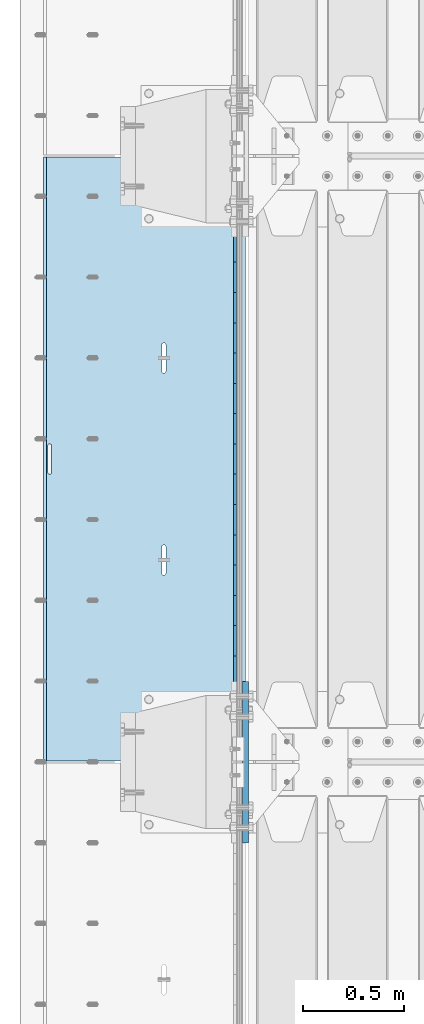
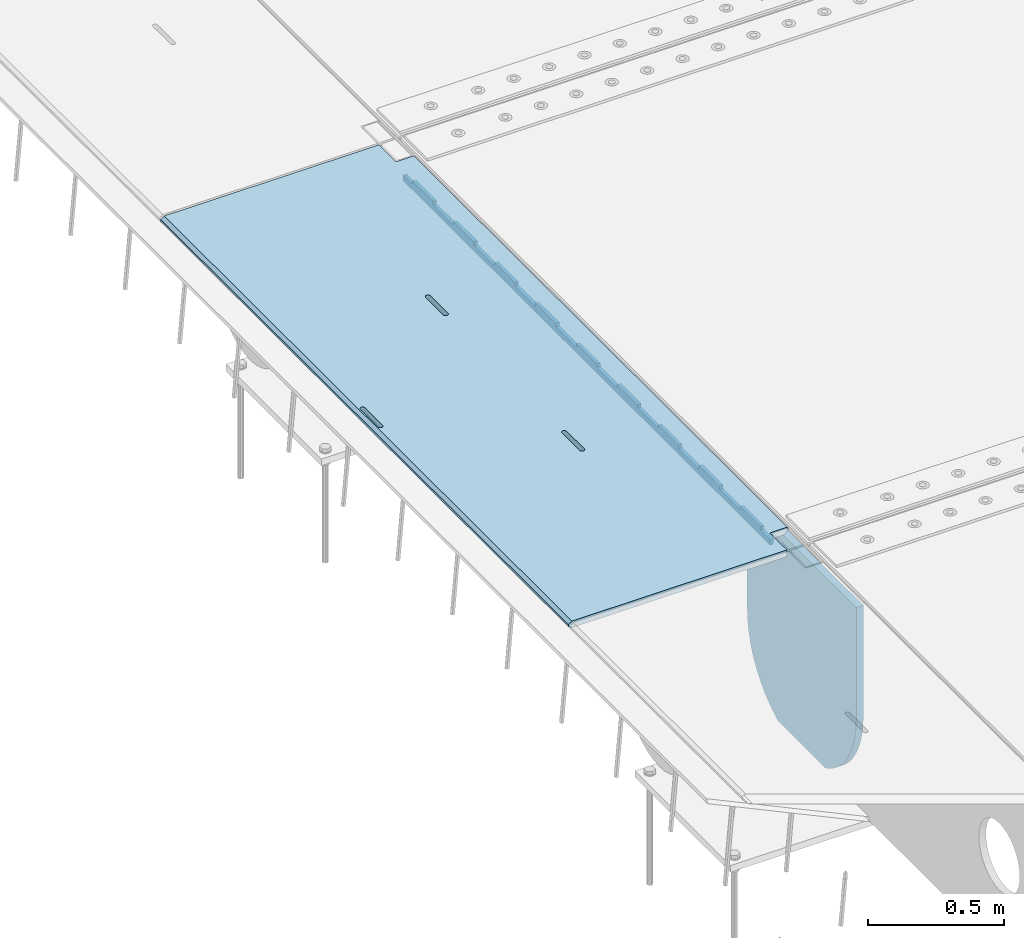
# One storey, part 185 of 240: 3 plates.
"""IFC2X3 building model written with IfcOpenShell, lengths in millimetres."""

from ifc_helpers import new_model, si_unit, frame, origin_with_axes, place, context, subcontext, project, spatial, faceted_brep, material, type_object, element, save


model = new_model("IFC2X3")

# Units and contexts
model_context = context("Model", 3, precision=1e-05, world=origin_with_axes())
body_context = subcontext(model_context, "Body", "Model", "MODEL_VIEW")
ifc_project = project(units=[si_unit("LENGTHUNIT", "METRE", prefix="MILLI"), si_unit("AREAUNIT", "SQUARE_METRE"), si_unit("VOLUMEUNIT", "CUBIC_METRE"), si_unit("MASSUNIT", "GRAM", prefix="KILO"), si_unit("TIMEUNIT", "SECOND"), si_unit("PLANEANGLEUNIT", "RADIAN"), si_unit("SOLIDANGLEUNIT", "STERADIAN"), si_unit("THERMODYNAMICTEMPERATUREUNIT", "DEGREE_CELSIUS"), si_unit("LUMINOUSINTENSITYUNIT", "LUMEN")], contexts=[model_context])

# Site, building, storey
site_placement = place(None, origin_with_axes())
site = spatial("IfcSite", under=ifc_project, at=site_placement, CompositionType="ELEMENT")
building_placement = place(site_placement, origin_with_axes())
building = spatial("IfcBuilding", under=site, at=building_placement, Name="Standard", CompositionType="ELEMENT")
storey_placement = place(building_placement, origin_with_axes())
storey = spatial("IfcBuildingStorey", under=building, at=storey_placement, Name="Undefined", CompositionType="ELEMENT", Elevation=0.0)

# Plates
ifc_material = material(Name="STEEL/S355N")
plate_type_1 = type_object("IfcPlateType", PredefinedType="NOTDEFINED")
plate_1_placement = place(storey_placement, frame((42392.5, 29845.0000994564, -36.018454190458), z_axis=(0.0, -0.999999999987744, -4.95099999993769e-06), x_axis=(0.0, 4.9510000093107e-06, -0.999999999987744)))
element("IfcPlate", 1, at=plate_1_placement, inside=storey, type_object=plate_type_1, material=ifc_material, context=body_context, shape_type="Brep", body=[
    faceted_brep([(7.105427357601e-15, -7.5, 0.0), (-1.24849464100407e-10, -7.5, 70.0), (-1.24849464100407e-10, 7.5, 70.0), (7.105427357601e-15, 7.5, 0.0), (-14.9899997711175, -7.5, 70.0), (-14.9899997711175, 7.5, 70.0), (-14.9899997711161, -7.5, 219.999999999996), (-14.9899997711161, 7.5, 219.999999999996), (-3.90826926377486e-10, -7.5, 220.0), (-3.90826926377486e-10, 7.5, 220.0), (-6.56825704936637e-10, -7.5, 369.999999999996), (-6.56825704936637e-10, 7.5, 369.999999999996), (-14.9899997711147, -7.5, 370.0), (-14.9899997711147, 7.5, 370.0), (-14.9899997711133, -7.5, 520.0), (-14.9899997711133, 7.5, 520.0), (-9.24622156617261e-10, -7.5, 520.0), (-9.24622156617261e-10, 7.5, 520.0), (-1.1906067243217e-09, -7.5, 670.0), (-1.1906067243217e-09, 7.5, 670.0), (-14.9899997711119, -7.5, 670.0), (-14.9899997711119, 7.5, 670.0), (-14.9899997711105, -7.5, 820.0), (-14.9899997711105, 7.5, 820.0), (-1.45477230262259e-09, -7.5, 819.999999999996), (-1.45477230262259e-09, 7.5, 819.999999999996), (-1.72258296515793e-09, -7.5, 970.0), (-1.72258296515793e-09, 7.5, 970.0), (-14.9899997711091, -7.5, 970.0), (-14.9899997711091, 7.5, 970.0), (-14.9899997711077, -7.5, 1120.0), (-14.9899997711077, 7.5, 1120.0), (-1.988560427435e-09, -7.5, 1120.0), (-1.988560427435e-09, 7.5, 1120.0), (-2.2545521005668e-09, -7.5, 1270.0), (-2.2545521005668e-09, 7.5, 1270.0), (-14.9899997711063, -7.5, 1270.0), (-14.9899997711063, 7.5, 1270.0), (-14.9899997711048, -7.5, 1420.0), (-14.9899997711048, 7.5, 1420.0), (-2.52235565767478e-09, -7.5, 1420.0), (-2.52235565767478e-09, 7.5, 1420.0), (-2.78834733080657e-09, -7.5, 1570.0), (-2.78834733080657e-09, 7.5, 1570.0), (-14.9899997711034, -7.5, 1570.0), (-14.9899997711034, 7.5, 1570.0), (-14.989999771102, -7.5, 1720.0), (-14.989999771102, 7.5, 1720.0), (-3.05432479308365e-09, -7.5, 1720.0), (-3.05432479308365e-09, 7.5, 1720.0), (-3.32212835019163e-09, -7.5, 1870.0), (-3.32212835019163e-09, 7.5, 1870.0), (-14.9899997711006, -7.5, 1870.0), (-14.9899997711006, 7.5, 1870.0), (-14.9899997710992, -7.5, 2020.0), (-14.9899997710992, 7.5, 2020.0), (-3.58812002332343e-09, -7.5, 2020.0), (-3.58812002332343e-09, 7.5, 2020.0), (-3.85410459102786e-09, -7.5, 2170.0), (-3.85410459102786e-09, 7.5, 2170.0), (-14.9899997710978, -7.5, 2170.0), (-14.9899997710978, 7.5, 2170.0), (-14.9899997710964, -7.5, 2320.0), (-14.9899997710964, 7.5, 2320.0), (-4.12190104270849e-09, -7.5, 2320.0), (-4.12190104270849e-09, 7.5, 2320.0), (-4.38789982126764e-09, -7.5, 2470.0), (-4.38789982126764e-09, 7.5, 2470.0), (-14.9999999999768, -7.5, 2470.0), (-14.9999999999768, 7.5, 2470.0), (-14.9899997710936, -7.5, 2620.0), (-14.9899997710936, 7.5, 2620.0), (-4.65387728354472e-09, -7.5, 2620.0), (-4.65387728354472e-09, 7.5, 2620.0), (-4.77872674764512e-09, -7.5, 2690.0), (-4.77872674764512e-09, 7.5, 2690.0), (25.0100002289071, -7.5, 2690.0), (25.0100002289071, 7.5, 2690.0), (25.0, -7.5, 0.0), (25.0, 7.5, 0.0)], [[[0, 1, 2, 3]], [[1, 4, 5, 2]], [[4, 6, 7, 5]], [[6, 8, 9, 7]], [[8, 10, 11, 9]], [[10, 12, 13, 11]], [[12, 14, 15, 13]], [[14, 16, 17, 15]], [[16, 18, 19, 17]], [[18, 20, 21, 19]], [[20, 22, 23, 21]], [[22, 24, 25, 23]], [[24, 26, 27, 25]], [[26, 28, 29, 27]], [[28, 30, 31, 29]], [[30, 32, 33, 31]], [[32, 34, 35, 33]], [[34, 36, 37, 35]], [[36, 38, 39, 37]], [[38, 40, 41, 39]], [[40, 42, 43, 41]], [[42, 44, 45, 43]], [[44, 46, 47, 45]], [[46, 48, 49, 47]], [[48, 50, 51, 49]], [[50, 52, 53, 51]], [[52, 54, 55, 53]], [[54, 56, 57, 55]], [[56, 58, 59, 57]], [[58, 60, 61, 59]], [[60, 62, 63, 61]], [[62, 64, 65, 63]], [[64, 66, 67, 65]], [[66, 68, 69, 67]], [[68, 70, 71, 69]], [[70, 72, 73, 71]], [[72, 74, 75, 73]], [[74, 76, 77, 75]], [[76, 78, 79, 77]], [[78, 0, 3, 79]], [[5, 7, 9, 11, 13, 15, 17, 19, 21, 23, 25, 27, 29, 31, 33, 35, 37, 39, 41, 43, 45, 47, 49, 51, 53, 55, 57, 59, 61, 63, 65, 67, 69, 71, 73, 75, 77, 79, 3, 2]], [[78, 76, 74, 72, 70, 68, 66, 64, 62, 60, 58, 56, 54, 52, 50, 48, 46, 44, 42, 40, 38, 36, 34, 32, 30, 28, 26, 24, 22, 20, 18, 16, 14, 12, 10, 8, 6, 4, 1, 0]]]),
])
plate_type_2 = type_object("IfcPlateType", PredefinedType="NOTDEFINED")
plate_2_placement = place(storey_placement, frame((42444.9962456697, 29994.9999261728, -1.00003031100477), z_axis=(0.0, -0.999999999987744, -4.95099999993769e-06), x_axis=(-0.999999999879068, -1.00000022173607e-09, -1.55519999981193e-05)))
element("IfcPlate", 2, at=plate_2_placement, inside=storey, type_object=plate_type_2, material=ifc_material, context=body_context, shape_type="Brep", body=[
    faceted_brep([(-0.000111589528387412, -5.71507111812863e-05, 2865.00000504127), (15.000238879169, 15.0, 2865.00008049106), (15.0000104223145, 15.0, 125.000079348185), (-0.000225737421715166, 5.71560163176166e-05, 125.00000363258), (999.996459960938, 5.0, 0.0), (984.996459960938, 15.0, 3.63797880709171e-12), (984.996459730719, 15.0, 2990.0), (999.996459730726, 5.0, 2990.0), (999.996459730726, -5.0, 2990.0), (984.99645973053, -15.0, 2990.0), (984.996459961367, -15.0, 0.0), (999.996459960938, -4.99999999999849, 0.0), (959.999522276543, -15.0000000031848, 1560.00000000859), (959.999522276543, 15.0, 1560.00000000858), (960.488957113346, 15.0, 1563.09016995233), (960.488957113346, -15.0000000031888, 1563.09016995233), (961.909352332339, 15.0, 1565.87785253151), (961.909352332339, -15.0000000032008, 1565.87785253151), (964.121669752989, 15.0, 1568.09016995233), (964.121669752989, -15.0000000032196, 1568.09016995233), (966.909352332048, 15.0, 1569.51056517153), (966.909352332055, -15.0000000032433, 1569.51056517153), (969.99952227575, 15.0, 1570.00000000859), (969.999522275757, -15.0000000032698, 1570.00000000859), (973.089692219539, 15.0, 1569.51056517153), (973.089692219546, -15.0000000032963, 1569.51056517154), (975.877374798838, 15.0, 1568.09016995233), (975.877374798831, -15.0000000033202, 1568.09016995233), (978.08969221983, 15.0, 1565.87785253151), (978.089692219837, -15.0000000033393, 1565.87785253151), (979.510087439237, 15.0, 1563.09016995232), (979.510087439237, -15.0000000033517, 1563.09016995232), (979.999522276528, 15.0, 1560.00000000857), (979.999522276528, -15.0000000033561, 1560.00000000857), (979.999522286394, 15.0, 1430.00000000857), (979.999522286394, -15.0000000033654, 1430.00000000857), (979.510087449584, 15.0, 1426.90983006483), (979.510087449584, -15.0000000033615, 1426.90983006483), (978.089692230598, 15.0, 1424.12214748565), (978.089692230591, -15.0000000033495, 1424.12214748566), (975.877374809941, 15.0, 1421.90983006484), (975.877374809941, -15.0000000033307, 1421.90983006483), (973.089692230875, 15.0, 1420.48943484563), (973.089692230875, -15.0000000033069, 1420.48943484563), (969.999522287326, 15.0, 1420.00000000858), (969.999522287326, -15.0000000032805, 1420.00000000859), (966.909352343537, 15.0, 1420.48943484563), (966.909352343544, -15.000000003254, 1420.48943484563), (964.121669764252, 15.0, 1421.90983006484), (964.121669764259, -15.00000000323, 1421.90983006484), (961.909352343268, 15.0, 1424.12214748566), (961.909352343268, -15.0000000032109, 1424.12214748566), (960.488957123845, 15.0, 1426.90983006483), (960.488957123845, -15.0000000031986, 1426.90983006483), (959.999522286562, 15.0, 1430.00000000858), (959.999522286562, -15.0000000031942, 1430.00000000859), (-0.000461898962385021, -14.9999999925605, 124.999928197292), (-0.000462055562820751, -14.9999999889596, 2864.99992960657), (75.0002624102563, 15.0, 125.00008047176), (74.999789880254, -15.0, 124.999929601763), (74.9997820615827, -15.0, 0.0), (75.0002485915757, 15.0, 0.0), (75.0005015106071, 15.0, 2990.0), (75.0000289806048, -15.0, 2990.0), (75.0004911355936, 15.0, 2865.00008054909), (75.0000186055913, -14.999999997918, 2864.99992967908), (395.488957121612, -15.0, 1926.90983006551), (395.488957121612, 15.0, 1926.90983006551), (394.999522284321, 15.0, 1930.00000000926), (394.999522284321, -15.0, 1930.00000000926), (396.909352341027, -15.0, 1924.12214748633), (396.909352341027, 15.0, 1924.12214748633), (399.121669762026, -15.0, 1921.90983006551), (399.121669762026, 15.0, 1921.90983006551), (401.90935234131, -15.0, 1920.48943484631), (401.909352341303, 15.0, 1920.48943484631), (404.999522285092, -15.0, 1920.00000000926), (404.999522285092, 15.0, 1920.00000000926), (408.08969222867, -15.0, 1920.48943484631), (408.089692228663, 15.0, 1920.48943484631), (410.877374807729, -15.0, 1921.90983006551), (410.877374807729, 15.0, 1921.90983006551), (413.089692228386, -15.0, 1924.12214748633), (413.089692228379, 15.0, 1924.12214748633), (414.510087447372, -15.0, 1926.9098300655), (414.510087447372, 15.0, 1926.9098300655), (414.99952228419, -15.0, 1930.00000000925), (414.999522284183, 15.0, 1930.00000000925), (414.999522274295, -15.0, 2060.00000000925), (414.999522274295, 15.0, 2060.00000000925), (414.510087437004, -15.0, 2063.090169953), (414.510087437004, 15.0, 2063.090169953), (413.089692217596, -15.0, 2065.87785253218), (413.089692217596, 15.0, 2065.87785253218), (410.87737479659, -15.0, 2068.09016995301), (410.87737479659, 15.0, 2068.09016995301), (408.08969221732, -15.0, 2069.51056517221), (408.08969221732, 15.0, 2069.51056517221), (404.999522273523, -15.0, 2070.00000000926), (404.999522273523, 15.0, 2070.00000000926), (401.909352329829, -15.0, 2069.51056517222), (401.909352329822, 15.0, 2069.51056517221), (399.121669750748, -15.0, 2068.09016995301), (399.121669750755, 15.0, 2068.09016995301), (396.909352330098, -15.0, 2065.87785253218), (396.909352330105, 15.0, 2065.87785253218), (395.488957111113, -15.0, 2063.090169953), (395.488957111113, 15.0, 2063.09016995301), (394.999522274302, -15.0, 2060.00000000926), (394.999522274302, 15.0, 2060.00000000926), (395.488957188121, -15.0, 1063.09016995165), (396.909352407107, -15.0, 1065.87785253083), (399.121669827764, -15.0, 1068.09016995166), (401.90935240683, -15.0, 1069.51056517086), (404.999522350525, -15.0, 1070.00000000791), (408.089692294321, -15.0, 1069.51056517086), (410.877374873606, -15.0, 1068.09016995166), (413.089692294605, -15.0, 1065.87785253083), (414.510087514012, -15.0, 1063.09016995165), (414.999522351303, -15.0, 1060.0000000079), (414.999522361191, -15.0, 930.000000007902), (414.510087524373, -15.0, 926.909830064153), (413.089692305402, -15.0, 924.122147484984), (410.877374884738, -15.0, 921.90983006416), (408.089692305679, -15.0, 920.489434844956), (404.999522362101, -15.0, 920.000000007909), (401.909352418326, -15.0, 920.489434844963), (399.121669839034, -15.0, 921.90983006416), (396.909352418043, -15.0, 924.122147484984), (395.488957198613, -15.0, 926.909830064156), (394.99952236133, -15.0, 930.000000007909), (394.999522351311, -15.0, 1060.00000000791), (396.909352418043, 15.0, 924.122147484984), (395.488957198613, 15.0, 926.909830064156), (399.121669839027, 15.0, 921.90983006416), (401.909352418319, 15.0, 920.48943484496), (404.999522362101, 15.0, 920.000000007905), (408.089692305672, 15.0, 920.489434844956), (410.877374884738, 15.0, 921.90983006416), (413.089692305395, 15.0, 924.122147484981), (414.510087524373, 15.0, 926.909830064149), (414.999522361184, 15.0, 930.000000007902), (414.999522351303, 15.0, 1060.0000000079), (414.51008751402, 15.0, 1063.09016995165), (413.089692294598, 15.0, 1065.87785253083), (410.877374873606, 15.0, 1068.09016995165), (408.089692294314, 15.0, 1069.51056517086), (404.999522350532, 15.0, 1070.00000000791), (401.90935240683, 15.0, 1069.51056517086), (399.121669827764, 15.0, 1068.09016995166), (396.909352407107, 15.0, 1065.87785253083), (395.488957188121, 15.0, 1063.09016995165), (394.999522351311, 15.0, 1060.00000000791), (394.99952236133, 15.0, 930.000000007909)], [[[0, 1, 2, 3]], [[4, 5, 6, 7]], [[8, 9, 10, 11]], [[12, 13, 14, 15]], [[15, 14, 16, 17]], [[17, 16, 18, 19]], [[19, 18, 20, 21]], [[21, 20, 22, 23]], [[23, 22, 24, 25]], [[25, 24, 26, 27]], [[27, 26, 28, 29]], [[29, 28, 30, 31]], [[31, 30, 32, 33]], [[33, 32, 34, 35]], [[35, 34, 36, 37]], [[37, 36, 38, 39]], [[39, 38, 40, 41]], [[41, 40, 42, 43]], [[43, 42, 44, 45]], [[45, 44, 46, 47]], [[47, 46, 48, 49]], [[49, 48, 50, 51]], [[51, 50, 52, 53]], [[53, 52, 54, 55]], [[55, 54, 13, 12]], [[56, 57, 0, 3]], [[58, 59, 56, 3, 2]], [[60, 59, 58, 61]], [[11, 10, 60, 61, 5, 4]], [[8, 11, 4, 7]], [[62, 63, 9, 8, 7, 6]], [[63, 62, 64, 65]], [[57, 65, 64, 1, 0]], [[66, 67, 68, 69]], [[70, 71, 67, 66]], [[72, 73, 71, 70]], [[74, 75, 73, 72]], [[76, 77, 75, 74]], [[78, 79, 77, 76]], [[80, 81, 79, 78]], [[82, 83, 81, 80]], [[84, 85, 83, 82]], [[86, 87, 85, 84]], [[88, 89, 87, 86]], [[90, 91, 89, 88]], [[92, 93, 91, 90]], [[94, 95, 93, 92]], [[96, 97, 95, 94]], [[98, 99, 97, 96]], [[100, 101, 99, 98]], [[102, 103, 101, 100]], [[104, 105, 103, 102]], [[106, 107, 105, 104]], [[108, 109, 107, 106]], [[69, 68, 109, 108]], [[63, 65, 57, 56, 59, 60, 10, 9], [15, 17, 19, 21, 23, 25, 27, 29, 31, 33, 35, 37, 39, 41, 43, 45, 47, 49, 51, 53, 55, 12], [110, 111, 112, 113, 114, 115, 116, 117, 118, 119, 120, 121, 122, 123, 124, 125, 126, 127, 128, 129, 130, 131], [106, 104, 102, 100, 98, 96, 94, 92, 90, 88, 86, 84, 82, 80, 78, 76, 74, 72, 70, 66, 69, 108]], [[128, 132, 133, 129]], [[127, 134, 132, 128]], [[126, 135, 134, 127]], [[125, 136, 135, 126]], [[124, 137, 136, 125]], [[123, 138, 137, 124]], [[122, 139, 138, 123]], [[121, 140, 139, 122]], [[120, 141, 140, 121]], [[119, 142, 141, 120]], [[118, 143, 142, 119]], [[117, 144, 143, 118]], [[116, 145, 144, 117]], [[115, 146, 145, 116]], [[114, 147, 146, 115]], [[113, 148, 147, 114]], [[112, 149, 148, 113]], [[111, 150, 149, 112]], [[110, 151, 150, 111]], [[131, 152, 151, 110]], [[130, 153, 152, 131]], [[129, 133, 153, 130]], [[64, 62, 6, 5, 61, 58, 2, 1], [50, 48, 46, 44, 42, 40, 38, 36, 34, 32, 30, 28, 26, 24, 22, 20, 18, 16, 14, 13, 54, 52], [132, 134, 135, 136, 137, 138, 139, 140, 141, 142, 143, 144, 145, 146, 147, 148, 149, 150, 151, 152, 153, 133], [71, 73, 75, 77, 79, 81, 83, 85, 87, 89, 91, 93, 95, 97, 99, 101, 103, 105, 107, 109, 68, 67]]]),
])
plate_type_3 = type_object("IfcPlateType", PredefinedType="NOTDEFINED")
plate_3_placement = place(storey_placement, frame((42445.0, 26600.0, -20.0), z_axis=(0.0, 1.0, 0.0), x_axis=(0.0, 0.0, -1.0)))
element("IfcPlate", 3, at=plate_3_placement, inside=storey, type_object=plate_type_3, material=ifc_material, context=body_context, shape_type="Brep", body=[
    faceted_brep([(855.0, -15.0, 572.96311467154), (855.0, 15.0, 572.96311467154), (849.182410261294, 15.0, 585.889268817533), (849.182410261294, -15.0, 585.889268817533), (824.193546357474, 15.0, 627.225898692486), (824.193546357474, -15.0, 627.225898692486), (794.404299268454, 15.0, 665.249063296338), (794.404299268454, -15.0, 665.249063296338), (760.249063296334, 15.0, 699.404299268463), (760.249063296334, -15.0, 699.404299268463), (722.22589869248, 15.0, 729.193546357485), (722.22589869248, -15.0, 729.193546357485), (680.889268817528, 15.0, 754.18241026131), (680.889268817528, -15.0, 754.18241026131), (636.841954817037, 15.0, 774.006497074195), (636.841954817037, -15.0, 774.006497074195), (590.726265715048, 15.0, 788.376726970448), (590.726265715048, -15.0, 788.376726970448), (543.214672102156, 15.0, 797.083549639254), (543.214672102156, -15.0, 797.083549639254), (495.0, -15.0, 800.000000000029), (495.0, 15.0, 800.0), (494.999999999412, -15.0, 0.0), (494.999999999412, 15.0, 0.0), (543.214672102129, 15.0, 2.91645036080809), (543.214672102129, -15.0, 2.91645036080809), (590.726265715023, 15.0, 11.6232730296069), (590.726265715023, -15.0, 11.6232730296069), (636.841954817014, 15.0, 25.9935029258631), (636.841954817014, -15.0, 25.9935029258631), (680.889268817507, 15.0, 45.8175897387446), (680.889268817507, -15.0, 45.8175897387446), (722.225898692462, 15.0, 70.8064536425663), (722.225898692462, -15.0, 70.8064536425663), (760.249063296318, 15.0, 100.595700731588), (760.249063296318, -15.0, 100.595700731588), (794.404299268441, 15.0, 134.750936703713), (794.404299268441, -15.0, 134.750936703713), (824.193546357463, 15.0, 172.774101307565), (824.193546357463, -15.0, 172.774101307565), (849.182410261284, 15.0, 214.110731182518), (849.182410261284, -15.0, 214.110731182518), (855.0, -15.0, 227.036885328533), (855.0, 15.0, 227.036885328533), (0.0, -15.0, 0.0), (0.0, 15.0, 0.0), (0.0, 15.0, 800.0), (0.0, -15.0, 800.0)], [[[0, 1, 2, 3]], [[3, 2, 4, 5]], [[5, 4, 6, 7]], [[7, 6, 8, 9]], [[9, 8, 10, 11]], [[11, 10, 12, 13]], [[13, 12, 14, 15]], [[15, 14, 16, 17]], [[17, 16, 18, 19]], [[20, 19, 18, 21]], [[22, 23, 24, 25]], [[25, 24, 26, 27]], [[27, 26, 28, 29]], [[29, 28, 30, 31]], [[31, 30, 32, 33]], [[33, 32, 34, 35]], [[35, 34, 36, 37]], [[37, 36, 38, 39]], [[39, 38, 40, 41]], [[42, 41, 40, 43]], [[42, 43, 1, 0]], [[44, 45, 23, 22]], [[16, 14, 12, 10, 8, 6, 4, 2, 1, 43, 40, 38, 36, 34, 32, 30, 28, 26, 24, 23, 45, 46, 21, 18]], [[44, 47, 46, 45]], [[46, 47, 20, 21]], [[47, 44, 22, 25, 27, 29, 31, 33, 35, 37, 39, 41, 42, 0, 3, 5, 7, 9, 11, 13, 15, 17, 19, 20]]]),
])

save(model, "model.ifc")
